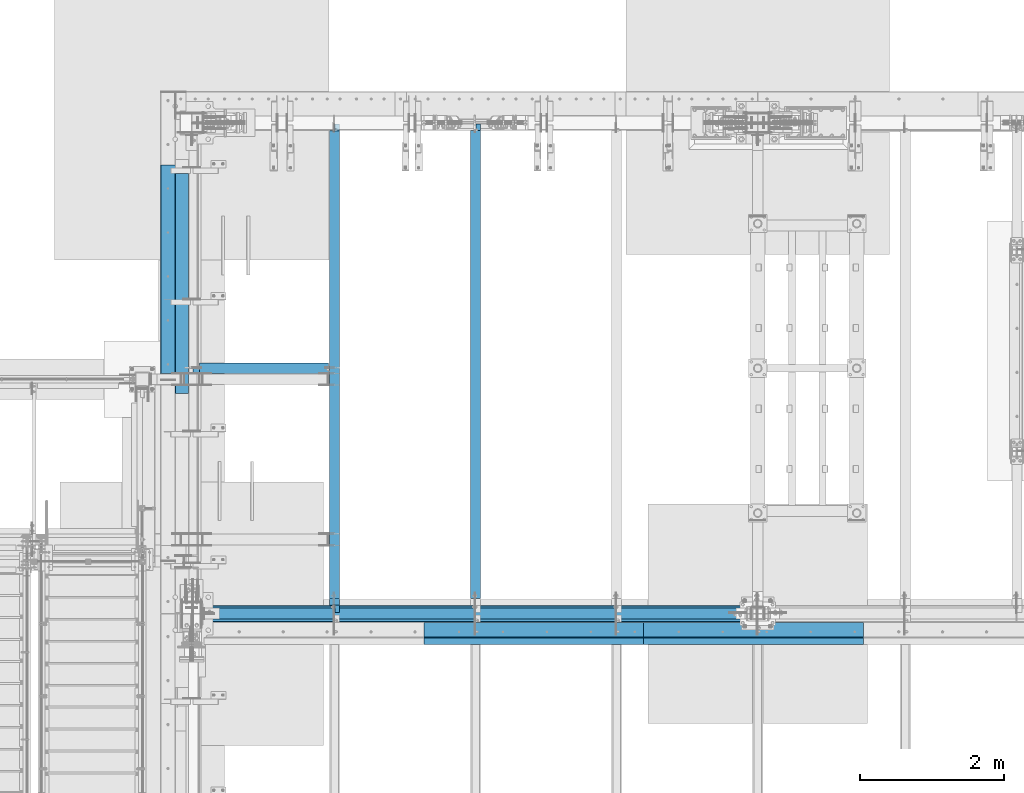
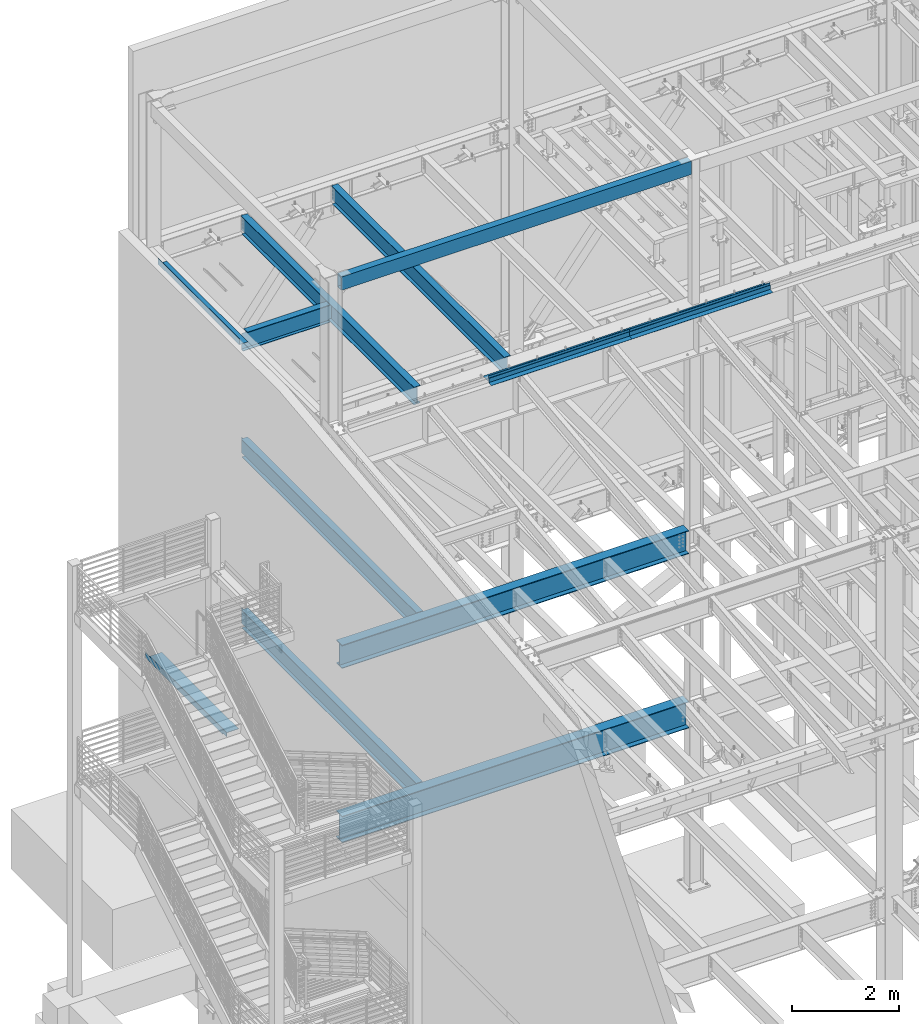
# One storey, part 766 of 1179: 14 beams, 13 elements without a shape of their own.
"""IFC2X3 building model written with IfcOpenShell, lengths in millimetres."""

from ifc_helpers import new_model, si_unit, frame, origin_with_axes, place, context, subcontext, project, spatial, faceted_brep, material, type_object, element, aggregate, save


model = new_model("IFC2X3")

# Units and contexts
model_context = context("Model", 3, precision=1e-05, world=origin_with_axes())
body_context = subcontext(model_context, "Body", "Model", "MODEL_VIEW")
ifc_project = project(units=[si_unit("LENGTHUNIT", "METRE", prefix="MILLI"), si_unit("AREAUNIT", "SQUARE_METRE"), si_unit("VOLUMEUNIT", "CUBIC_METRE"), si_unit("MASSUNIT", "GRAM", prefix="KILO"), si_unit("TIMEUNIT", "SECOND"), si_unit("PLANEANGLEUNIT", "RADIAN"), si_unit("SOLIDANGLEUNIT", "STERADIAN"), si_unit("THERMODYNAMICTEMPERATUREUNIT", "DEGREE_CELSIUS"), si_unit("LUMINOUSINTENSITYUNIT", "LUMEN")], contexts=[model_context])

# Site, building, storey
site_placement = place(None, origin_with_axes())
site = spatial("IfcSite", under=ifc_project, at=site_placement, CompositionType="ELEMENT")
building_placement = place(site_placement, origin_with_axes())
building = spatial("IfcBuilding", under=site, at=building_placement, Name="Undefined", CompositionType="ELEMENT")
storey_placement = place(building_placement, origin_with_axes())
storey = spatial("IfcBuildingStorey", under=building, at=storey_placement, Name="Undefined", CompositionType="ELEMENT", Elevation=0.0)

# Assembly, beam
assembly_1_placement = place(storey_placement, origin_with_axes())
assembly_1 = element("IfcElementAssembly", 1, at=assembly_1_placement, inside=storey, Name="BEAM", AssemblyPlace="NOTDEFINED", PredefinedType="RIGID_FRAME")
ifc_material_1 = material(Name="STEEL/A992")
beam_type_1 = type_object("IfcBeamType", Name="W16X31", PredefinedType="NOTDEFINED")
beam_1_placement = place(assembly_1_placement, frame((431.799999999999, 37795.2, 12917.4875), z_axis=(0.0, 0.0, 1.0), x_axis=(1.0, 0.0, 0.0)))
beam_1 = element("IfcBeam", 2, at=beam_1_placement, type_object=beam_type_1, material=ifc_material_1, Name="BEAM", ObjectType="W16X31", context=body_context, shape_type="Brep", body=[
    faceted_brep([(1898.65, -3.17499999999927, -190.5), (1898.65, -69.8499999999985, -190.5), (1898.65, -69.8499999999985, -201.6125), (1898.65, 69.8499999999985, -201.6125), (1898.65, 69.8499999999985, -190.5), (1898.65, 3.17499999999927, -190.5), (1898.65, 3.17520505924767, -182.562499809268), (1898.65, -3.17499999999927, -182.562499809265), (1899.61672992259, 3.17520183817396, -177.702420291222), (1899.61672992259, -3.17499999999927, -177.70242029122), (1902.36974382307, 3.175199107558, -173.582243823068), (1902.36974382306, -3.17499999999927, -173.582243823066), (1906.48992029122, 3.17519728311891, -170.82922992259), (1906.48992029122, -3.17499999999927, -170.829229922588), (1911.34999980926, 3.17519664260908, -169.862500000003), (1911.34999980926, -3.17499999999927, -169.8625), (1965.325, -3.17499999999927, -169.8625), (1965.325, 3.17499999999927, -169.8625), (108.743750000001, 3.17500000000291, 190.5), (108.743750000001, 69.8499999999985, 190.5), (1898.65, 69.8499999999985, 190.5), (1898.65, 3.17499999999927, 190.5), (145.256250000001, 69.8499999999985, -190.5), (145.256250000001, 69.8499999999985, -201.612499999999), (145.256250000001, 3.17549991607666, -201.612499999999), (145.256250000001, 3.17549991607666, -190.5), (18.2562500000006, 3.17549991607666, -201.612499999999), (18.2562500000006, 3.17500000000291, -190.5), (18.2562500000006, -69.8499999999985, -201.612499999999), (18.2562500000006, -69.8499999999985, -190.5), (18.2562500000006, -3.17500000000291, -190.5), (18.2562500000006, -3.17500000000291, 163.512499999999), (18.2562500000006, 3.17500000000291, 163.512499999999), (96.0437501907355, -3.17500000000291, 163.512499999999), (96.0437501907355, 3.1749750851086, 163.512499999999), (100.903829708781, -3.17500000000291, 164.479229922586), (100.903829708781, 3.17497445087793, 164.479229922586), (105.024006176935, -3.17500000000291, 167.232243823064), (105.024006176935, 3.17497264474514, 167.232243823064), (107.777020077413, -3.17500000000291, 171.352420291218), (107.777020077413, 3.17496994166868, 171.352420291218), (108.743750000001, -3.17500000000291, 176.212499809264), (108.743750000001, 3.1749667531767, 176.212499809264), (108.743750000001, -69.8499999999985, 201.612499999999), (108.743750000001, 69.8499999999985, 201.612499999999), (108.743750000001, -3.17500000000291, 190.5), (108.743750000001, -69.8499999999985, 190.5), (1898.65, -3.17499999999927, 190.5), (1898.65, -69.8499999999985, 190.5), (1898.65, -69.8499999999985, 201.6125), (1898.65, 69.8499999999985, 201.6125), (1898.65, -3.17499999999927, 182.562499809265), (1898.65, 3.17499999999927, 182.562499809265), (1899.61672992259, -3.17499999999927, 177.70242029122), (1899.61672992259, 3.17499999999927, 177.70242029122), (1902.36974382306, -3.17499999999927, 173.582243823066), (1902.36974382306, 3.17499999999927, 173.582243823066), (1906.48992029122, -3.17499999999927, 170.829229922588), (1906.48992029122, 3.17499999999927, 170.829229922588), (1911.34999980926, -3.17499999999927, 169.8625), (1911.34999980926, 3.17499999999927, 169.8625), (1965.325, -3.17499999999927, 169.8625), (1965.325, 3.17499999999927, 169.8625)], [[[0, 1, 2, 3, 4, 5, 6, 7]], [[7, 6, 8, 9]], [[9, 8, 10, 11]], [[11, 10, 12, 13]], [[13, 12, 14, 15]], [[16, 15, 14, 17]], [[18, 19, 20, 21]], [[22, 23, 24, 25]], [[25, 24, 26, 27]], [[27, 26, 28, 29, 30, 31, 32]], [[33, 34, 32, 31]], [[35, 36, 34, 33]], [[37, 38, 36, 35]], [[39, 40, 38, 37]], [[41, 42, 40, 39]], [[43, 44, 19, 18, 42, 41, 45, 46]], [[46, 45, 47, 48]], [[43, 46, 48, 49]], [[44, 43, 49, 50]], [[19, 44, 50, 20]], [[49, 48, 47, 51, 52, 21, 20, 50]], [[53, 54, 52, 51]], [[55, 56, 54, 53]], [[57, 58, 56, 55]], [[59, 60, 58, 57]], [[61, 62, 60, 59]], [[62, 61, 16, 17]], [[12, 10, 8, 6, 5, 25, 27, 32, 34, 36, 38, 40, 42, 18, 21, 52, 54, 56, 58, 60, 62, 17, 14]], [[22, 25, 5, 4]], [[23, 22, 4, 3]], [[28, 26, 24, 23, 3, 2]], [[29, 28, 2, 1]], [[30, 29, 1, 0]], [[61, 59, 57, 55, 53, 51, 47, 45, 41, 39, 37, 35, 33, 31, 30, 0, 7, 9, 11, 13, 15, 16]]]),
])
aggregate(assembly_1, [beam_1])

assembly_2_placement = place(storey_placement, origin_with_axes())
assembly_2 = element("IfcElementAssembly", 3, at=assembly_2_placement, inside=storey, Name="BEAM", AssemblyPlace="NOTDEFINED", PredefinedType="RIGID_FRAME")
beam_2_placement = place(assembly_2_placement, frame((4368.8, 34391.6, 12917.4875), z_axis=(0.0, 0.0, 1.0), x_axis=(0.0, 1.0, 0.0)))
beam_2 = element("IfcBeam", 4, at=beam_2_placement, type_object=beam_type_1, material=ifc_material_1, Name="BEAM", ObjectType="W16X31", context=body_context, shape_type="Brep", body=[
    faceted_brep([(212.724999999999, 69.8499999999985, -190.5), (212.724999999999, 3.17499999999927, -190.5), (6661.94375000001, 3.17499999999927, -190.5), (6661.94375000001, 69.8499999999985, -190.5), (212.724999999999, -3.17499999999927, -190.5), (212.724999999999, -69.8499999999985, -190.5), (6788.94375000001, -69.8499999999985, -190.5), (6788.94375000001, -3.17499999999927, -190.5), (212.724999999999, -69.8499999999985, -201.612499999999), (6788.94375000001, -69.8499999999985, -201.612499999999), (6788.94375000001, 3.17544885756979, -201.612499999999), (6788.94375000001, 3.17499999999927, -190.5), (6788.94375000001, 3.17499999999927, 163.512499999999), (6788.94375000001, -3.17499999999927, 163.512499999999), (6661.94375000001, 3.17544885756979, -201.612499999999), (212.724999999999, 69.8499999999985, -201.612499999999), (6661.94375000001, 69.8499999999985, -201.612499999999), (212.724999999999, -3.17499999999927, 190.5), (212.724999999999, -69.8499999999985, 190.5), (212.724999999999, -69.8499999999985, 201.612499999999), (212.724999999999, 69.8499999999985, 201.612499999999), (212.724999999999, 69.8499999999985, 190.5), (212.724999999999, 3.17499999999927, 190.5), (212.724999999999, 3.17499999999927, 162.664998864024), (212.724999999999, 3.17499999999927, -142.027500567505), (6696.86875000001, 69.8499999999985, 190.5), (6696.86875000001, 3.17499999999927, 190.5), (6696.86875000001, 3.17499999999927, 176.212499809264), (6697.8354799226, 3.17499999999927, 171.352420291218), (6700.58849382307, 3.17499999999927, 167.232243823064), (6704.70867029123, 3.17499999999927, 164.479229922586), (6709.56874980927, 3.17499999999927, 163.512499999999), (6697.8354799226, -3.17499999999927, 171.352420291218), (6696.86875000001, -3.17499999999927, 176.212499809264), (6700.58849382307, -3.17499999999927, 167.232243823064), (6704.70867029123, -3.17499999999927, 164.479229922586), (6709.56874980927, -3.17499999999927, 163.512499999999), (6696.86875000001, -3.17499999999927, 190.5), (6696.86875000001, -69.8499999999985, 190.5), (6696.86875000001, -69.8499999999985, 201.612499999999), (6696.86875000001, 69.8499999999985, 201.612499999999)], [[[0, 1, 2, 3]], [[4, 5, 6, 7]], [[5, 8, 9, 6]], [[7, 6, 9, 10, 11, 12, 13]], [[11, 10, 14, 2]], [[9, 8, 15, 16, 14, 10]], [[2, 14, 16, 3]], [[15, 0, 3, 16]], [[8, 5, 4, 17, 18, 19, 20, 21, 22, 23, 24, 1, 0, 15]], [[22, 21, 25, 26]], [[11, 2, 1, 24, 23, 22, 26, 27, 28, 29, 30, 31, 12]], [[32, 28, 27, 33]], [[34, 29, 28, 32]], [[35, 30, 29, 34]], [[36, 31, 30, 35]], [[13, 12, 31, 36]], [[35, 34, 32, 33, 37, 17, 4, 7, 13, 36]], [[18, 17, 37, 38]], [[19, 18, 38, 39]], [[20, 19, 39, 40]], [[21, 20, 40, 25]], [[39, 38, 37, 33, 27, 26, 25, 40]]]),
])
aggregate(assembly_2, [beam_2])

assembly_3_placement = place(storey_placement, origin_with_axes())
assembly_3 = element("IfcElementAssembly", 5, at=assembly_3_placement, inside=storey, Name="BEAM", AssemblyPlace="NOTDEFINED", PredefinedType="RIGID_FRAME")
beam_3_placement = place(assembly_3_placement, frame((2413.0, 34391.6, 12917.4875), z_axis=(0.0, 0.0, 1.0), x_axis=(0.0, 1.0, 0.0)))
beam_3 = element("IfcBeam", 6, at=beam_3_placement, type_object=beam_type_1, material=ifc_material_1, Name="BEAM", ObjectType="W16X31", context=body_context, shape_type="Brep", body=[
    faceted_brep([(212.724999999999, 69.8499999999985, -190.5), (212.724999999999, 3.17499999999927, -190.5), (6661.94375000001, 3.17499999999927, -190.5), (6661.94375000001, 69.8499999999985, -190.5), (212.724999999999, -3.17499999999927, -190.5), (212.724999999999, -69.8499999999985, -190.5), (6788.94375000001, -69.8499999999985, -190.5), (6788.94375000001, -3.17499999999927, -190.5), (212.724999999999, -69.8499999999985, -201.612499999999), (6788.94375000001, -69.8499999999985, -201.612499999999), (6788.94375000001, 3.17549991607666, -201.612499999999), (6788.94375000001, 3.17499999999927, -190.5), (6788.94375000001, 3.17499999999927, 163.512499999999), (6788.94375000001, -3.17499999999927, 163.512499999999), (6661.94375000001, 3.17549991607666, -201.612499999999), (212.724999999999, 69.8499999999985, -201.612499999999), (6661.94375000001, 69.8499999999985, -201.612499999999), (212.724999999999, -3.17499999999927, 190.5), (212.724999999999, -69.8499999999985, 190.5), (212.724999999999, -69.8499999999985, 201.612499999999), (212.724999999999, 69.8499999999985, 201.612499999999), (212.724999999999, 69.8499999999985, 190.5), (212.724999999999, 3.17499999999927, 190.5), (212.724999999999, 3.17499999999927, 162.664998864024), (212.724999999999, 3.17499999999927, -142.027500567505), (6696.86875000001, 69.8499999999985, 190.5), (6696.86875000001, 3.17499999999927, 190.5), (6696.86875000001, 3.17499999999927, 176.212499809264), (6697.8354799226, 3.17499999999927, 171.352420291218), (6700.58849382307, 3.17499999999927, 167.232243823064), (6704.70867029123, 3.17499999999927, 164.479229922586), (6709.56874980927, 3.17499999999927, 163.512499999999), (6697.8354799226, -3.17499999999927, 171.352420291218), (6696.86875000001, -3.17499999999927, 176.212499809264), (6700.58849382307, -3.17499999999927, 167.232243823064), (6704.70867029123, -3.17499999999927, 164.479229922586), (6709.56874980927, -3.17499999999927, 163.512499999999), (6696.86875000001, -3.17499999999927, 190.5), (6696.86875000001, -69.8499999999985, 190.5), (6696.86875000001, -69.8499999999985, 201.612499999999), (6696.86875000001, 69.8499999999985, 201.612499999999)], [[[0, 1, 2, 3]], [[4, 5, 6, 7]], [[5, 8, 9, 6]], [[7, 6, 9, 10, 11, 12, 13]], [[11, 10, 14, 2]], [[9, 8, 15, 16, 14, 10]], [[2, 14, 16, 3]], [[15, 0, 3, 16]], [[8, 5, 4, 17, 18, 19, 20, 21, 22, 23, 24, 1, 0, 15]], [[22, 21, 25, 26]], [[11, 2, 1, 24, 23, 22, 26, 27, 28, 29, 30, 31, 12]], [[32, 28, 27, 33]], [[34, 29, 28, 32]], [[35, 30, 29, 34]], [[36, 31, 30, 35]], [[13, 12, 31, 36]], [[35, 34, 32, 33, 37, 17, 4, 7, 13, 36]], [[18, 17, 37, 38]], [[19, 18, 38, 39]], [[20, 19, 39, 40]], [[21, 20, 40, 25]], [[39, 38, 37, 33, 27, 26, 25, 40]]]),
])
aggregate(assembly_3, [beam_3])

assembly_4_placement = place(storey_placement, origin_with_axes())
assembly_4 = element("IfcElementAssembly", 7, at=assembly_4_placement, inside=storey, Name="BEAM", AssemblyPlace="NOTDEFINED", PredefinedType="RIGID_FRAME")
beam_4_placement = place(assembly_4_placement, frame((2413.0, 34391.6, 7812.0875), z_axis=(0.0, 0.0, 1.0), x_axis=(0.0, 1.0, 0.0)))
beam_4 = element("IfcBeam", 8, at=beam_4_placement, type_object=beam_type_1, material=ifc_material_1, Name="BEAM", ObjectType="W16X31", context=body_context, shape_type="Brep", body=[
    faceted_brep([(104.775000190733, -3.17499999999927, 166.6875), (104.775000190733, 3.17497120592088, 166.6875), (17.4624999999942, 3.17499999999927, 166.6875), (17.4624999999942, -3.17499999999927, 166.6875), (109.63507970878, -3.17499999999927, 167.654229922588), (109.63507970878, 3.17497058299341, 167.654229922588), (113.755256176933, -3.17499999999927, 170.407243823066), (113.755256176933, 3.17496880904946, 170.407243823066), (116.508270077407, -3.17499999999927, 174.52742029122), (116.508270077407, 3.17496615415439, 174.52742029122), (117.474999999999, -3.17499999999927, 179.387499809265), (117.474999999999, 3.17496302249128, 179.387499809265), (117.474999999999, -69.8499999999985, 201.6125), (117.474999999999, 69.8499999999985, 201.6125), (117.474999999999, 69.8499999999985, 190.5), (117.474999999999, 3.17499999999927, 190.5), (117.474999999999, -3.17499999999927, 190.5), (117.474999999999, -69.8499999999985, 190.5), (6660.35625, 3.17499999999927, -190.5), (6660.35625, 69.8500000000004, -190.5), (144.462499999994, 69.8499999999985, -190.5), (144.462499999994, 3.17549991607666, -190.5), (17.4624999999942, -3.17499999999927, -190.5), (17.4624999999942, -69.8499999999985, -190.5), (6787.35625, -69.8500000000004, -190.5), (6787.35625, -3.17499999999927, -190.5), (17.4624999999942, -69.8499999999985, -201.6125), (6787.35625, -69.8500000000004, -201.6125), (6660.35625, 69.8500000000004, -201.6125), (6660.35625, 3.17549991607484, -201.6125), (6787.35625, 3.17549991607484, -201.6125), (17.4624999999942, 3.17549991607666, -201.6125), (144.462499999994, 3.17549991607666, -201.6125), (144.462499999994, 69.8499999999985, -201.6125), (17.4624999999942, 3.17499999999927, -190.5), (6787.35625, 3.17499999999927, -190.5), (6787.35625, 3.17499999999927, 157.1625), (6787.35625, -3.17499999999927, 157.1625), (6700.04374980927, 3.17499999999927, 157.1625), (6700.04374980927, -3.17499999999927, 157.1625), (6695.18367029123, 3.17499999999927, 158.129229922588), (6695.18367029123, -3.17499999999927, 158.129229922588), (6691.06349382307, 3.17499999999927, 160.882243823066), (6691.06349382307, -3.17499999999927, 160.882243823066), (6688.31047992259, 3.17499999999927, 165.00242029122), (6688.31047992259, -3.17499999999927, 165.00242029122), (6687.34375000001, 3.17499999999927, 169.862499809266), (6687.34375000001, -3.17499999999927, 169.862499809266), (6687.34375000001, -69.8500000000004, 201.6125), (6687.34375000001, -69.8500000000004, 190.5), (6687.34375000001, -3.17499999999927, 190.5), (6687.34375000001, 3.17499999999927, 190.5), (6687.34375000001, 69.8500000000004, 190.5), (6687.34375000001, 69.8500000000004, 201.6125)], [[[0, 1, 2, 3]], [[4, 5, 1, 0]], [[6, 7, 5, 4]], [[8, 9, 7, 6]], [[10, 11, 9, 8]], [[12, 13, 14, 15, 11, 10, 16, 17]], [[18, 19, 20, 21]], [[22, 23, 24, 25]], [[23, 26, 27, 24]], [[28, 29, 30, 27, 26, 31, 32, 33]], [[21, 32, 31, 34]], [[20, 33, 32, 21]], [[19, 28, 33, 20]], [[18, 29, 28, 19]], [[35, 30, 29, 18]], [[25, 24, 27, 30, 35, 36, 37]], [[37, 36, 38, 39]], [[39, 38, 40, 41]], [[41, 40, 42, 43]], [[43, 42, 44, 45]], [[45, 44, 46, 47]], [[48, 49, 50, 47, 46, 51, 52, 53]], [[49, 48, 12, 17]], [[50, 49, 17, 16]], [[8, 6, 4, 0, 3, 22, 25, 37, 39, 41, 43, 45, 47, 50, 16, 10]], [[34, 31, 26, 23, 22, 3, 2]], [[51, 46, 44, 42, 40, 38, 36, 35, 18, 21, 34, 2, 1, 5, 7, 9, 11, 15]], [[52, 51, 15, 14]], [[53, 52, 14, 13]], [[48, 53, 13, 12]]]),
])
aggregate(assembly_4, [beam_4])

assembly_5_placement = place(storey_placement, origin_with_axes())
assembly_5 = element("IfcElementAssembly", 9, at=assembly_5_placement, inside=storey, Name="BEAM", AssemblyPlace="NOTDEFINED", PredefinedType="RIGID_FRAME")
beam_5_placement = place(assembly_5_placement, frame((2412.99985351563, 34391.6, 3900.4875), z_axis=(0.0, 0.0, 1.0), x_axis=(0.0, 1.0, 0.0)))
beam_5 = element("IfcBeam", 10, at=beam_5_placement, type_object=beam_type_1, material=ifc_material_1, Name="BEAM", ObjectType="W16X31", context=body_context, shape_type="Brep", body=[
    faceted_brep([(18.2562500000006, -69.8499999999985, -190.5), (18.2562500000006, -69.8499999999985, -201.612499999999), (6787.35625, -69.8500000000004, -201.6125), (6787.35625, -69.8500000000004, -190.5), (6660.35625, 69.8500000000004, -201.6125), (6660.35625, 3.1754070527486, -201.6125), (6787.35625, 3.1754070527486, -201.6125), (18.2562500793938, 3.17558455032122, -201.6125), (145.256250079394, 3.17558137532069, -201.6125), (145.256250000001, 69.8499999999985, -201.612499999999), (145.256250079394, 3.17558137532069, -190.5), (18.2562500000006, 3.17500000000291, -190.5), (145.256250000001, 69.8499999999985, -190.5), (6660.35625, 3.17499999999927, -190.5), (6660.35625, 69.8500000000004, -190.5), (6787.35625, 3.17499999999927, -190.5), (6787.35625, -3.17499999999927, -190.5), (6787.35625007939, 3.17500000129257, 163.512499999999), (6787.35624992065, -3.17499999870779, 163.512499999999), (18.2562500000006, -3.17500000000291, -190.5), (18.2562514952835, -3.17499999999927, 169.8625), (18.2562514952835, 3.17499999999927, 169.8625), (113.506251936145, -3.17499999997744, 169.8625), (113.506251936145, 3.17496422017757, 169.8625), (118.366331454192, -3.17499999997926, 170.829229922588), (118.366331454192, 3.17496349569046, 170.829229922588), (122.486507922345, -3.17499999997744, 173.582243823066), (122.486507922345, 3.17496143253265, 173.582243823066), (125.239521822827, -3.17499999997563, 177.70242029122), (125.239521822819, 3.17495834479632, 177.70242029122), (126.206251745411, -3.17499999997744, 182.562499809265), (126.206251745411, 3.1749547025629, 182.562499809265), (126.206251745432, -69.8499999999767, 201.6125), (126.206251745396, 69.850000000024, 201.6125), (126.206251745396, 69.850000000024, 190.5), (126.206251745418, 3.17500000002292, 190.5), (126.206251745411, -3.17499999997744, 190.5), (126.206251745432, -69.8499999999767, 190.5), (6687.34375000001, 69.8500000000004, 190.5), (6687.34375000001, 3.17499999999927, 190.5), (6687.3437517463, 3.17494718995658, 176.212499809265), (6688.31048166887, 3.17500000127438, 171.352420291219), (6691.06349556935, 3.17500000127438, 167.232243823065), (6695.18367203751, 3.1750000012762, 164.479229922587), (6700.04375155555, 3.1750000012762, 163.512499999999), (6688.31048166887, -3.17499999872598, 171.352420291219), (6687.34375174629, -3.17499999872598, 176.212499809265), (6691.06349556935, -3.17499999872598, 167.232243823065), (6695.18367203751, -3.17499999872416, 164.479229922587), (6700.04375155555, -3.17499999872416, 163.512499999999), (6687.34375000001, -3.17499999999927, 190.5), (6687.34375000001, -69.8500000000004, 190.5), (6687.34375000001, -69.8500000000004, 201.6125), (6687.34375000001, 69.8500000000004, 201.6125)], [[[0, 1, 2, 3]], [[4, 5, 6, 2, 1, 7, 8, 9]], [[10, 8, 7, 11]], [[12, 9, 8, 10]], [[13, 14, 12, 10]], [[14, 4, 9, 12]], [[13, 5, 4, 14]], [[15, 6, 5, 13]], [[16, 3, 2, 6, 15, 17, 18]], [[19, 0, 3, 16]], [[11, 7, 1, 0, 19, 20, 21]], [[22, 23, 21, 20]], [[24, 25, 23, 22]], [[26, 27, 25, 24]], [[28, 29, 27, 26]], [[30, 31, 29, 28]], [[32, 33, 34, 35, 31, 30, 36, 37]], [[38, 39, 35, 34]], [[15, 13, 10, 11, 21, 23, 25, 27, 29, 31, 35, 39, 40, 41, 42, 43, 44, 17]], [[45, 41, 40, 46]], [[47, 42, 41, 45]], [[48, 43, 42, 47]], [[49, 44, 43, 48]], [[18, 17, 44, 49]], [[28, 26, 24, 22, 20, 19, 16, 18, 49, 48, 47, 45, 46, 50, 36, 30]], [[50, 51, 37, 36]], [[51, 52, 32, 37]], [[52, 53, 33, 32]], [[53, 38, 34, 33]], [[52, 51, 50, 46, 40, 39, 38, 53]]]),
])
aggregate(assembly_5, [beam_5])

assembly_6_placement = place(storey_placement, origin_with_axes())
assembly_6 = element("IfcElementAssembly", 11, at=assembly_6_placement, inside=storey, Name="BEAM", AssemblyPlace="NOTDEFINED", PredefinedType="RIGID_FRAME")
ifc_material_2 = material(Name="STEEL/A36")
beam_type_2 = type_object("IfcBeamType", PredefinedType="NOTDEFINED")
beam_6_placement = place(assembly_6_placement, frame((388.937, 38969.9848191647, 13122.275), z_axis=(0.0, -1.0, 0.0), x_axis=(-1.0, 0.0, 0.0)))
beam_6 = element("IfcBeam", 12, at=beam_6_placement, type_object=beam_type_2, material=ifc_material_2, Name="BENT_PLATE", context=body_context, shape_type="Brep", body=[
    faceted_brep([(0.0, -3.17499999999927, -1524.0), (6.00266503170133e-10, -3.17499999922438, 1524.00000000052), (6.00266503170133e-10, 3.17500000077416, 1524.00000000052), (0.0, 3.17499999999927, -1524.0), (185.737000000001, 3.17499999999927, 1524.0), (185.737000000001, 3.17499999999927, -1524.0), (179.387000000001, -3.17499999999927, -1524.0), (179.387000000001, -3.17499999999927, 1524.0), (185.737000000001, -130.175000000001, 1524.0), (185.737000000001, -130.175000000001, -1524.0), (179.387000000001, -130.175000000001, 1524.0), (179.387000000001, -130.175000000001, -1524.0)], [[[0, 1, 2, 3]], [[3, 2, 4, 5]], [[1, 0, 6, 7]], [[5, 4, 8, 9]], [[4, 2, 1, 7, 10, 8]], [[7, 6, 11, 10]], [[6, 0, 3, 5, 9, 11]], [[10, 11, 9, 8]]]),
])
aggregate(assembly_6, [beam_6])

assembly_7_placement = place(storey_placement, origin_with_axes())
assembly_7 = element("IfcElementAssembly", 13, at=assembly_7_placement, inside=storey, Name="BENT_PLATE", AssemblyPlace="NOTDEFINED", PredefinedType="RIGID_FRAME")
beam_type_3 = type_object("IfcBeamType", PredefinedType="NOTDEFINED")
beam_7_placement = place(assembly_7_placement, frame((8221.66250082126, 34061.4000000402, 13197.7319337816), z_axis=(1.0, 0.0, 0.0), x_axis=(0.0, 0.0, -1.0)))
beam_7 = element("IfcBeam", 14, at=beam_7_placement, type_object=beam_type_3, material=ifc_material_2, Name="BENT_PLATE", context=body_context, shape_type="Brep", body=[
    faceted_brep([(0.0, -3.17499999999927, -1524.0), (6.00266503170133e-10, -3.17499999922438, 1524.00000000052), (6.00266503170133e-10, 3.17500000077416, 1524.00000000052), (0.0, 3.17499999999927, -1524.0), (101.599999999993, 3.17500000000291, 1524.0), (101.599999999993, 3.17500000000291, -1524.0), (95.9271295501057, -3.17500000000291, -1524.0), (95.9271295501057, -3.17500000000291, 1524.0), (113.008063243053, -97.7824964679457, 1524.0), (113.008063243053, -97.7824964679457, -1524.0), (106.698219713815, -98.4955004206422, 1524.0), (106.698219713815, -98.4955004206422, -1524.0)], [[[0, 1, 2, 3]], [[3, 2, 4, 5]], [[1, 0, 6, 7]], [[5, 4, 8, 9]], [[4, 2, 1, 7, 10, 8]], [[7, 6, 11, 10]], [[6, 0, 3, 5, 9, 11]], [[10, 11, 9, 8]]]),
])
aggregate(assembly_7, [beam_7])

assembly_8_placement = place(storey_placement, origin_with_axes())
assembly_8 = element("IfcElementAssembly", 15, at=assembly_8_placement, inside=storey, Name="BENT_PLATE", AssemblyPlace="NOTDEFINED", PredefinedType="RIGID_FRAME")
beam_8_placement = place(assembly_8_placement, frame((5173.66250081041, 34061.4000000402, 13197.7319337816), z_axis=(1.0, 0.0, 0.0), x_axis=(0.0, 0.0, -1.0)))
beam_8 = element("IfcBeam", 16, at=beam_8_placement, type_object=beam_type_3, material=ifc_material_2, Name="BENT_PLATE", context=body_context, shape_type="Brep", body=[
    faceted_brep([(0.0, -3.17499999999927, -1524.0), (6.00266503170133e-10, -3.17499999922438, 1524.00000000052), (6.00266503170133e-10, 3.17500000077416, 1524.00000000052), (0.0, 3.17499999999927, -1524.0), (101.599999999993, 3.17500000000291, 1524.0), (101.599999999993, 3.17500000000291, -1524.0), (95.9271295501057, -3.17500000000291, -1524.0), (95.9271295501057, -3.17500000000291, 1524.0), (113.008063243053, -97.7824964679457, 1524.0), (113.008063243053, -97.7824964679457, -1524.0), (106.698219713815, -98.4955004206422, 1524.0), (106.698219713815, -98.4955004206422, -1524.0)], [[[0, 1, 2, 3]], [[3, 2, 4, 5]], [[1, 0, 6, 7]], [[5, 4, 8, 9]], [[4, 2, 1, 7, 10, 8]], [[7, 6, 11, 10]], [[6, 0, 3, 5, 9, 11]], [[10, 11, 9, 8]]]),
])
aggregate(assembly_8, [beam_8])

# Assembly, beams
assembly_9_placement = place(storey_placement, origin_with_axes())
assembly_9 = element("IfcElementAssembly", 17, at=assembly_9_placement, inside=storey, Name="BEAM", AssemblyPlace="NOTDEFINED", PredefinedType="RIGID_FRAME")
beam_type_4 = type_object("IfcBeamType", PredefinedType="NOTDEFINED")
beam_9_placement = place(assembly_9_placement, frame((8221.66250081644, 34267.775, 13122.275), z_axis=(1.0, 0.0, 0.0), x_axis=(0.0, -1.0, 0.0)))
beam_9 = element("IfcBeam", 18, at=beam_9_placement, type_object=beam_type_4, material=ifc_material_2, Name="BENT_PLATE", context=body_context, shape_type="Brep", body=[
    faceted_brep([(0.0, -3.17499999999927, -1524.0), (6.00266503170133e-10, -3.17499999922438, 1524.00000000052), (6.00266503170133e-10, 3.17500000077416, 1524.00000000052), (0.0, 3.17499999999927, -1524.0), (203.199999999997, 3.17499999999927, 1524.0), (203.199999999997, 3.17499999999927, -1524.0), (196.849999999991, -3.17499999999927, -1524.0), (196.849999999991, -3.17499999999927, 1524.0), (203.199999999997, -130.175000000001, 1524.0), (203.199999999997, -130.175000000001, -1524.0), (196.849999999991, -130.175000000001, 1524.0), (196.849999999991, -130.175000000001, -1524.0)], [[[0, 1, 2, 3]], [[3, 2, 4, 5]], [[1, 0, 6, 7]], [[5, 4, 8, 9]], [[4, 2, 1, 7, 10, 8]], [[7, 6, 11, 10]], [[6, 0, 3, 5, 9, 11]], [[10, 11, 9, 8]]]),
])
beam_10_placement = place(assembly_9_placement, frame((5173.66250081644, 34267.775, 13122.275), z_axis=(1.0, 0.0, 0.0), x_axis=(0.0, -1.0, 0.0)))
beam_10 = element("IfcBeam", 19, at=beam_10_placement, type_object=beam_type_4, material=ifc_material_2, Name="BENT_PLATE", context=body_context, shape_type="Brep", body=[
    faceted_brep([(0.0, -3.17499999999927, -1524.0), (6.00266503170133e-10, -3.17499999922438, 1524.00000000052), (6.00266503170133e-10, 3.17500000077416, 1524.00000000052), (0.0, 3.17499999999927, -1524.0), (203.199999999997, 3.17499999999927, 1524.0), (203.199999999997, 3.17499999999927, -1524.0), (196.849999999991, -3.17499999999927, -1524.0), (196.849999999991, -3.17499999999927, 1524.0), (203.199999999997, -130.175000000001, 1524.0), (203.199999999997, -130.175000000001, -1524.0), (196.849999999991, -130.175000000001, 1524.0), (196.849999999991, -130.175000000001, -1524.0)], [[[0, 1, 2, 3]], [[3, 2, 4, 5]], [[1, 0, 6, 7]], [[5, 4, 8, 9]], [[4, 2, 1, 7, 10, 8]], [[7, 6, 11, 10]], [[6, 0, 3, 5, 9, 11]], [[10, 11, 9, 8]]]),
])
aggregate(assembly_9, [beam_9, beam_10])

# Assembly, beam
assembly_10_placement = place(storey_placement, origin_with_axes())
assembly_10 = element("IfcElementAssembly", 20, at=assembly_10_placement, inside=storey, Name="BEAM", AssemblyPlace="NOTDEFINED", PredefinedType="RIGID_FRAME")
beam_type_5 = type_object("IfcBeamType", PredefinedType="NOTDEFINED")
beam_11_placement = place(assembly_10_placement, frame((352.424987792969, 39090.5999988819, 4105.275), z_axis=(0.0, -1.0, 0.0), x_axis=(-1.0, 0.0, 0.0)))
beam_11 = element("IfcBeam", 21, at=beam_11_placement, type_object=beam_type_5, material=ifc_material_2, Name="BENT_PLATE", context=body_context, shape_type="Brep", body=[
    faceted_brep([(352.424987792969, 3.17499999999927, 1365.25000072263), (346.074987492094, 3.17499999999927, 1365.25000118611), (346.074987792969, -3.17500000000109, 1365.25000118611), (346.074987717209, -34.9250000000002, 1365.25000074806), (352.424987792969, -34.9250000000002, 1365.25000072264), (352.424987792969, -34.9249999999993, 1523.99999992021), (346.074987616774, -34.9249999999993, 1523.99999970536), (58.7374874920944, -3.17500000000018, 1365.25000111779), (58.7374874920944, 3.17500000000018, 1365.25000111779), (0.0, 3.17500000000018, 1365.25000213296), (0.0, -3.17500000000018, 1365.25000213233), (0.0, 3.17499999999927, -1524.0), (0.0, -3.17499999999927, -1524.0), (346.074987792969, -3.17500000000109, -1524.0), (346.074987792969, -130.175006103515, 1524.0), (352.424987792969, -130.175006103515, 1524.0), (346.074987792969, -130.175006103515, -1524.0), (346.074987792969, -130.175006103515, 1365.25000118611), (352.424987792969, -130.175006103515, -1524.0), (352.424987792969, 3.17499999999927, -1524.0)], [[[0, 1, 2, 3, 4]], [[5, 4, 3, 6]], [[7, 8, 9, 10]], [[11, 12, 10, 9]], [[12, 13, 2, 7, 10]], [[14, 15, 5, 6]], [[2, 13, 16, 17, 14, 6, 3]], [[14, 17, 16, 18, 15]], [[13, 12, 11, 19, 18, 16]], [[15, 18, 19, 0, 4, 5]], [[19, 11, 9, 8, 1, 0]], [[2, 1, 8, 7]]]),
])
aggregate(assembly_10, [beam_11])

assembly_11_placement = place(storey_placement, origin_with_axes())
assembly_11 = element("IfcElementAssembly", 22, at=assembly_11_placement, inside=storey, Name="BEAM", AssemblyPlace="NOTDEFINED", PredefinedType="RIGID_FRAME")
ifc_material_3 = material()
beam_type_6 = type_object("IfcBeamType", Name="HSS12X6X3/8", PredefinedType="NOTDEFINED")
beam_12_placement = place(assembly_11_placement, frame((601.6625, 34391.6, 16275.05), z_axis=(0.0, 0.0, 1.0), x_axis=(1.0, 0.0, 0.0)))
beam_12 = element("IfcBeam", 23, at=beam_12_placement, type_object=beam_type_6, material=ifc_material_3, Name="BEAM", ObjectType="HSS12X6X3/8", context=body_context, shape_type="Brep", body=[
    faceted_brep([(4.76249999999709, 66.6749999999993, -142.875), (4.76249999999709, -66.6749999999993, -142.875), (7585.075, -66.6750000000029, -142.875), (7585.075, 66.6750000000029, -142.875), (4.76249999999709, -66.6749999999993, 142.875000000002), (7585.075, -66.6750000000029, 142.875000000002), (4.76249999999709, 66.6749999999993, 142.875000000002), (7585.075, 66.6750000000029, 142.875000000002), (4.76249999999709, 76.2000000000007, -152.4), (4.76249999999709, 76.2000000000007, 152.4), (7585.075, 76.1999999999971, 152.4), (7585.075, 76.1999999999971, -152.4), (4.76249999999709, -76.2000000000007, 152.4), (7585.075, -76.1999999999971, 152.4), (4.76249999999709, -76.2000000000007, -152.4), (7585.075, -76.1999999999971, -152.4)], [[[0, 1, 2, 3]], [[1, 4, 5, 2]], [[4, 6, 7, 5]], [[6, 0, 3, 7]], [[8, 9, 10, 11]], [[9, 12, 13, 10]], [[12, 14, 15, 13]], [[14, 8, 11, 15]], [[13, 15, 11, 10], [5, 7, 3, 2]], [[14, 12, 9, 8], [6, 4, 1, 0]]]),
])
aggregate(assembly_11, [beam_12])

assembly_12_placement = place(storey_placement, origin_with_axes())
assembly_12 = element("IfcElementAssembly", 24, at=assembly_12_placement, inside=storey, Name="BEAM", AssemblyPlace="NOTDEFINED", PredefinedType="RIGID_FRAME")
beam_type_7 = type_object("IfcBeamType", Name="W21X62", PredefinedType="NOTDEFINED")
beam_13_placement = place(assembly_12_placement, frame((431.8, 34391.6, 7747.0), z_axis=(0.0, 0.0, 1.0), x_axis=(1.0, 0.0, 0.0)))
beam_13 = element("IfcBeam", 25, at=beam_13_placement, type_object=beam_type_7, material=ifc_material_1, Name="BEAM", ObjectType="W21X62", context=body_context, shape_type="Brep", body=[
    faceted_brep([(169.862500816437, -104.775000000001, -266.7), (169.862500816437, 104.775000000001, -266.7), (7680.325, 104.775000000001, -266.7), (7680.325, -104.775000000001, -266.7), (169.862500816437, -104.775000000001, -250.825), (169.8625, -4.76250000000073, -250.825), (169.8625, -4.76250000000073, 250.825), (169.862500816437, -104.775000000001, 250.825), (169.862500816437, -104.775000000001, 266.7), (169.862500816437, 104.775000000001, 266.7), (169.862500816437, 104.775000000001, 250.825), (169.8625, 4.76250000000073, 250.825), (169.8625, 4.76250000000073, -250.825), (169.862500816437, 104.775000000001, -250.825), (7680.325, -104.775000000001, -250.825), (7680.325, -4.76249999999709, -250.825), (7680.325, -4.76249999999709, 250.825), (7680.325, -104.775000000001, 250.825), (7680.325, -104.775000000001, 266.7), (7680.325, 104.775000000001, 266.7), (7680.325, 104.775000000001, 250.825), (7680.325, 4.76249999999709, 250.825), (7680.325, 4.76249999999709, -250.825), (7680.325, 104.775000000001, -250.825)], [[[0, 1, 2, 3]], [[0, 4, 5, 6, 7, 8, 9, 10, 11, 12, 13, 1]], [[5, 4, 14, 15]], [[6, 5, 15, 16]], [[7, 6, 16, 17]], [[8, 7, 17, 18]], [[9, 8, 18, 19]], [[10, 9, 19, 20]], [[11, 10, 20, 21]], [[12, 11, 21, 22]], [[13, 12, 22, 23]], [[1, 13, 23, 2]], [[22, 21, 20, 19, 18, 17, 16, 15, 14, 3, 2, 23]], [[4, 0, 3, 14]]]),
])
aggregate(assembly_12, [beam_13])

assembly_13_placement = place(storey_placement, origin_with_axes())
assembly_13 = element("IfcElementAssembly", 26, at=assembly_13_placement, inside=storey, Name="BEAM", AssemblyPlace="NOTDEFINED", PredefinedType="RIGID_FRAME")
beam_type_8 = type_object("IfcBeamType", Name="W24X68", PredefinedType="NOTDEFINED")
beam_14_placement = place(assembly_13_placement, frame((431.8, 34391.6, 3800.475), z_axis=(0.0, 0.0, 1.0), x_axis=(1.0, 0.0, 0.0)))
beam_14 = element("IfcBeam", 27, at=beam_14_placement, type_object=beam_type_8, material=ifc_material_1, Name="BEAM", ObjectType="W24X68", context=body_context, shape_type="Brep", body=[
    faceted_brep([(169.8625, -114.299999999999, -301.625), (169.8625, 114.299999999999, -301.625), (7680.325, 114.300000000003, -301.625), (7680.325, -114.300000000003, -301.625), (169.8625, -114.299999999999, -287.3375), (169.8625, -5.55625000000146, -287.3375), (169.8625, -5.55625000000146, 287.3375), (169.8625, -114.299999999999, 287.3375), (169.8625, -114.299999999999, 301.625), (169.8625, 114.299999999999, 301.625), (169.8625, 114.299999999999, 287.3375), (169.8625, 5.55625000000146, 287.3375), (169.8625, 5.55625000000146, -287.3375), (169.8625, 114.299999999999, -287.3375), (7680.325, -114.300000000003, -287.3375), (7680.325, -5.55625000000146, -287.3375), (7680.325, -5.55625000000146, 287.3375), (7680.325, -114.300000000003, 287.3375), (7680.325, -114.300000000003, 301.625), (7680.325, 114.300000000003, 301.625), (7680.325, 114.300000000003, 287.3375), (7680.325, 5.55625000000146, 287.3375), (7680.325, 5.55625000000146, -287.3375), (7680.325, 114.300000000003, -287.3375)], [[[0, 1, 2, 3]], [[0, 4, 5, 6, 7, 8, 9, 10, 11, 12, 13, 1]], [[5, 4, 14, 15]], [[6, 5, 15, 16]], [[7, 6, 16, 17]], [[8, 7, 17, 18]], [[9, 8, 18, 19]], [[10, 9, 19, 20]], [[11, 10, 20, 21]], [[12, 11, 21, 22]], [[13, 12, 22, 23]], [[1, 13, 23, 2]], [[22, 21, 20, 19, 18, 17, 16, 15, 14, 3, 2, 23]], [[4, 0, 3, 14]]]),
])
aggregate(assembly_13, [beam_14])

save(model, "model.ifc")
